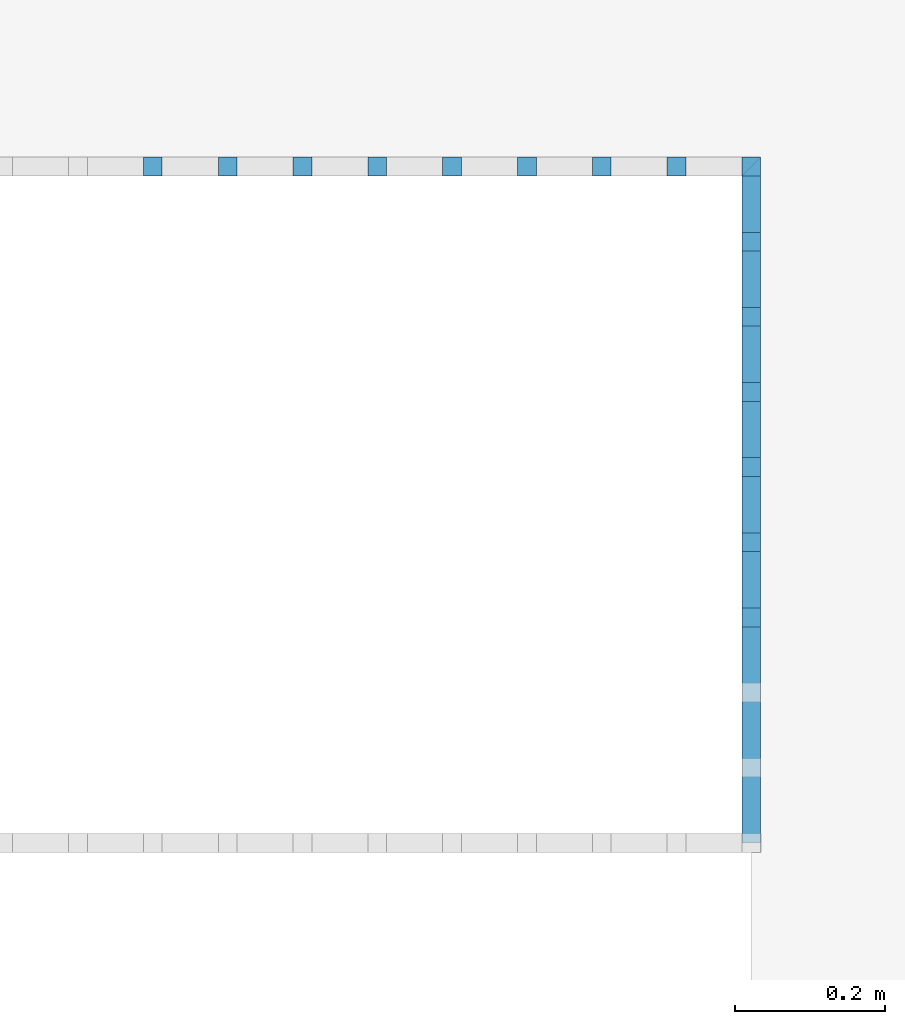
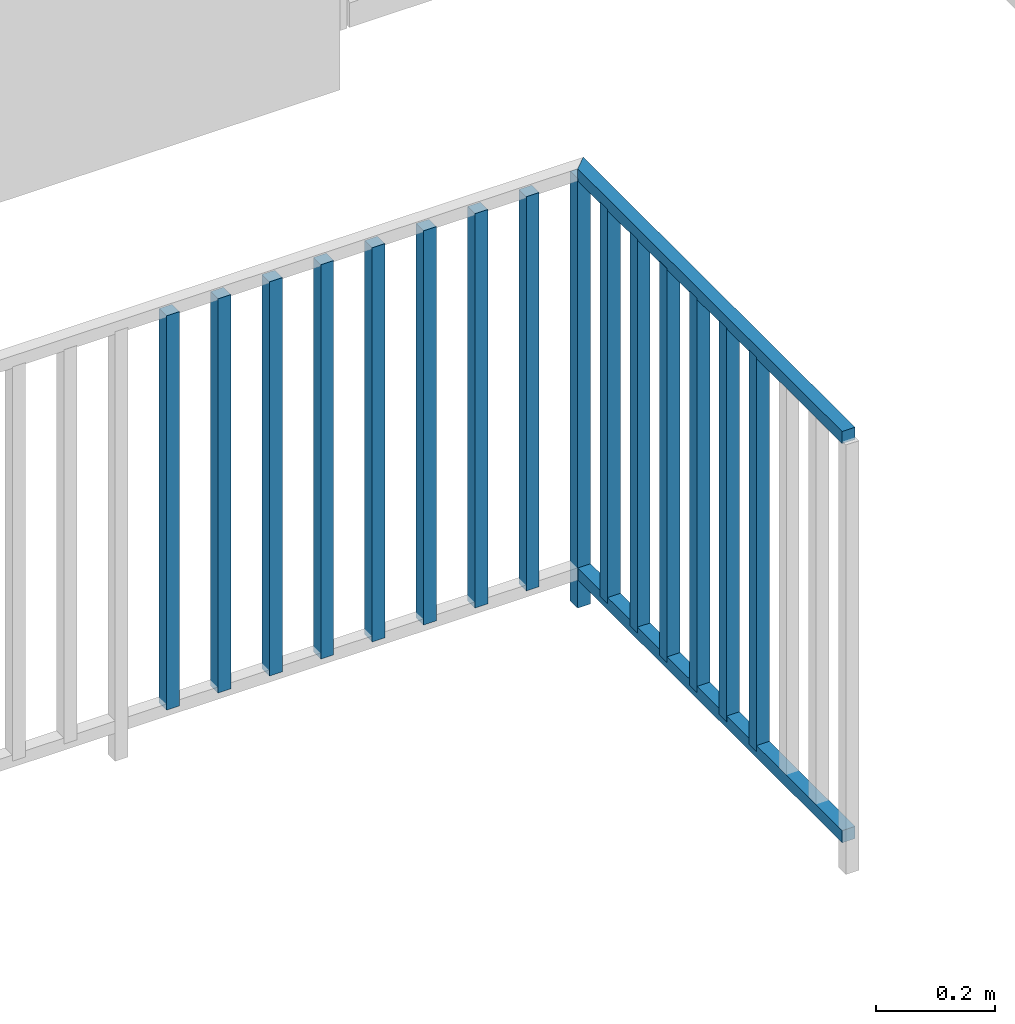
# One storey, part 41 of 54: 17 building element parts, 1 element without a shape of its own.
"""IFC4 building model written with IfcOpenShell, lengths in metres."""

from ifc_helpers import new_model, entity, si_unit, converted_unit, derived_unit, direction, frame, origin_with_axes, place, context, subcontext, project, spatial, polygons, material, type_object, element, aggregate, save


model = new_model("IFC4")

# Units and contexts
model_context = context("Model", 3, precision=1e-05, world=origin_with_axes(), true_north=direction((0.0, 1.0)))
body_context = subcontext(model_context, "Body", "Model", "MODEL_VIEW")
ifc_project = project(units=[si_unit("LENGTHUNIT", "METRE"), si_unit("AREAUNIT", "SQUARE_METRE"), si_unit("VOLUMEUNIT", "CUBIC_METRE"), converted_unit("PLANEANGLEUNIT", "DEGREE", entity("IfcPlaneAngleMeasure", 0.0174532925199), si_unit("PLANEANGLEUNIT", "RADIAN"), dimensions=[0, 0, 0, 0, 0, 0, 0]), converted_unit("TIMEUNIT", "Year", entity("IfcTimeMeasure", 31556926.0), si_unit("TIMEUNIT", "SECOND"), dimensions=[0, 0, 1, 0, 0, 0, 0]), si_unit("MASSUNIT", "GRAM", prefix="KILO"), si_unit("THERMODYNAMICTEMPERATUREUNIT", "DEGREE_CELSIUS"), si_unit("LUMINOUSINTENSITYUNIT", "LUMEN"), si_unit("ENERGYUNIT", "JOULE", prefix="MEGA"), derived_unit("THERMALCONDUCTANCEUNIT", [(si_unit("POWERUNIT", "WATT"), 1), (si_unit("LENGTHUNIT", "METRE"), -1), (si_unit("THERMODYNAMICTEMPERATUREUNIT", "KELVIN"), -1)]), derived_unit("SPECIFICHEATCAPACITYUNIT", [(si_unit("ENERGYUNIT", "JOULE"), 1), (si_unit("MASSUNIT", "GRAM", prefix="KILO"), -1), (si_unit("THERMODYNAMICTEMPERATUREUNIT", "KELVIN"), -1)]), derived_unit("MASSDENSITYUNIT", [(si_unit("MASSUNIT", "GRAM", prefix="KILO"), 1), (si_unit("VOLUMEUNIT", "CUBIC_METRE"), -1)])], contexts=[model_context])

# Site, building, storey, space
site_placement = place(None, origin_with_axes())
site = spatial("IfcSite", under=ifc_project, at=site_placement, CompositionType="ELEMENT")
building_placement = place(site_placement, origin_with_axes())
building = spatial("IfcBuilding", under=site, at=building_placement, CompositionType="ELEMENT")
storey_placement = place(building_placement, frame((0.0, 0.0, 6.29), z_axis=(0.0, 0.0, 1.0), x_axis=(1.0, 0.0, 0.0)))
storey = spatial("IfcBuildingStorey", under=building, at=storey_placement, Name="2. Geschoss", CompositionType="ELEMENT", Elevation=6.29)
space_placement = place(storey_placement, frame((-3.4421993804, -2.52881223104, 0.0), z_axis=(0.0, 0.0, 1.0), x_axis=(1.0, 0.0, 0.0)))
space = spatial("IfcSpace", under=storey, at=space_placement, CompositionType="ELEMENT", PredefinedType="INTERNAL")

# Railing, building element parts
railing_type = type_object("IfcRailingType", PredefinedType="NOTDEFINED")
railing_placement = place(space_placement, frame((0.0, 1.5, 0.0), z_axis=(0.0, 0.0, 1.0), x_axis=(1.0, 0.0, 0.0)))
railing = element("IfcRailing", 1, at=railing_placement, inside=space, type_object=railing_type, PredefinedType="NOTDEFINED")
ifc_material = material()
building_element_part_1_placement = place(railing_placement, origin_with_axes())
building_element_part_1 = element("IfcBuildingElementPart", 2, at=building_element_part_1_placement, material=ifc_material, PredefinedType="NOTDEFINED", context=body_context, shape_type="Tessellation", body=[
    polygons([(4.4925, 0.8875, 0.0), (4.4925, 0.9125, 0.0), (4.4925, 0.9125, 0.88), (4.4925, 0.8875, 0.88), (4.4675, 0.8875, 0.0), (4.4675, 0.9125, 0.0), (4.4675, 0.9125, 0.88), (4.4675, 0.8875, 0.88)], [[[1, 2, 3, 4]], [[1, 5, 6, 2]], [[2, 6, 7, 3]], [[4, 3, 7, 8]], [[5, 1, 4, 8]], [[6, 5, 8, 7]]], closed=True),
])
building_element_part_2_placement = place(railing_placement, origin_with_axes())
building_element_part_2 = element("IfcBuildingElementPart", 3, at=building_element_part_2_placement, material=ifc_material, PredefinedType="NOTDEFINED", context=body_context, shape_type="Tessellation", body=[
    polygons([(3.69605555556, 0.8875, 0.07), (3.69605555556, 0.9125, 0.07), (3.69605555556, 0.9125, 0.8775), (3.69605555556, 0.8875, 0.8775), (3.67105555556, 0.8875, 0.07), (3.67105555556, 0.9125, 0.07), (3.67105555556, 0.9125, 0.8775), (3.67105555556, 0.8875, 0.8775)], [[[1, 2, 3, 4]], [[1, 5, 6, 2]], [[2, 6, 7, 3]], [[4, 3, 7, 8]], [[5, 1, 4, 8]], [[6, 5, 8, 7]]], closed=True),
])
building_element_part_3_placement = place(railing_placement, origin_with_axes())
building_element_part_3 = element("IfcBuildingElementPart", 4, at=building_element_part_3_placement, material=ifc_material, PredefinedType="NOTDEFINED", context=body_context, shape_type="Tessellation", body=[
    polygons([(3.79561111111, 0.8875, 0.07), (3.79561111111, 0.9125, 0.07), (3.79561111111, 0.9125, 0.8775), (3.79561111111, 0.8875, 0.8775), (3.77061111111, 0.8875, 0.07), (3.77061111111, 0.9125, 0.07), (3.77061111111, 0.9125, 0.8775), (3.77061111111, 0.8875, 0.8775)], [[[1, 2, 3, 4]], [[1, 5, 6, 2]], [[2, 6, 7, 3]], [[4, 3, 7, 8]], [[5, 1, 4, 8]], [[6, 5, 8, 7]]], closed=True),
])
building_element_part_4_placement = place(railing_placement, origin_with_axes())
building_element_part_4 = element("IfcBuildingElementPart", 5, at=building_element_part_4_placement, material=ifc_material, PredefinedType="NOTDEFINED", context=body_context, shape_type="Tessellation", body=[
    polygons([(3.89516666667, 0.8875, 0.07), (3.89516666667, 0.9125, 0.07), (3.89516666667, 0.9125, 0.8775), (3.89516666667, 0.8875, 0.8775), (3.87016666667, 0.8875, 0.07), (3.87016666667, 0.9125, 0.07), (3.87016666667, 0.9125, 0.8775), (3.87016666667, 0.8875, 0.8775)], [[[1, 2, 3, 4]], [[1, 5, 6, 2]], [[2, 6, 7, 3]], [[4, 3, 7, 8]], [[5, 1, 4, 8]], [[6, 5, 8, 7]]], closed=True),
])
building_element_part_5_placement = place(railing_placement, origin_with_axes())
building_element_part_5 = element("IfcBuildingElementPart", 6, at=building_element_part_5_placement, material=ifc_material, PredefinedType="NOTDEFINED", context=body_context, shape_type="Tessellation", body=[
    polygons([(3.99472222222, 0.8875, 0.07), (3.99472222222, 0.9125, 0.07), (3.99472222222, 0.9125, 0.8775), (3.99472222222, 0.8875, 0.8775), (3.96972222222, 0.8875, 0.07), (3.96972222222, 0.9125, 0.07), (3.96972222222, 0.9125, 0.8775), (3.96972222222, 0.8875, 0.8775)], [[[1, 2, 3, 4]], [[1, 5, 6, 2]], [[2, 6, 7, 3]], [[4, 3, 7, 8]], [[5, 1, 4, 8]], [[6, 5, 8, 7]]], closed=True),
])
building_element_part_6_placement = place(railing_placement, origin_with_axes())
building_element_part_6 = element("IfcBuildingElementPart", 7, at=building_element_part_6_placement, material=ifc_material, PredefinedType="NOTDEFINED", context=body_context, shape_type="Tessellation", body=[
    polygons([(4.09427777778, 0.8875, 0.07), (4.09427777778, 0.9125, 0.07), (4.09427777778, 0.9125, 0.8775), (4.09427777778, 0.8875, 0.8775), (4.06927777778, 0.8875, 0.07), (4.06927777778, 0.9125, 0.07), (4.06927777778, 0.9125, 0.8775), (4.06927777778, 0.8875, 0.8775)], [[[1, 2, 3, 4]], [[1, 5, 6, 2]], [[2, 6, 7, 3]], [[4, 3, 7, 8]], [[5, 1, 4, 8]], [[6, 5, 8, 7]]], closed=True),
])
building_element_part_7_placement = place(railing_placement, origin_with_axes())
building_element_part_7 = element("IfcBuildingElementPart", 8, at=building_element_part_7_placement, material=ifc_material, PredefinedType="NOTDEFINED", context=body_context, shape_type="Tessellation", body=[
    polygons([(4.19383333333, 0.8875, 0.07), (4.19383333333, 0.9125, 0.07), (4.19383333333, 0.9125, 0.8775), (4.19383333333, 0.8875, 0.8775), (4.16883333333, 0.8875, 0.07), (4.16883333333, 0.9125, 0.07), (4.16883333333, 0.9125, 0.8775), (4.16883333333, 0.8875, 0.8775)], [[[1, 2, 3, 4]], [[1, 5, 6, 2]], [[2, 6, 7, 3]], [[4, 3, 7, 8]], [[5, 1, 4, 8]], [[6, 5, 8, 7]]], closed=True),
])
building_element_part_8_placement = place(railing_placement, origin_with_axes())
building_element_part_8 = element("IfcBuildingElementPart", 9, at=building_element_part_8_placement, material=ifc_material, PredefinedType="NOTDEFINED", context=body_context, shape_type="Tessellation", body=[
    polygons([(4.29338888889, 0.8875, 0.07), (4.29338888889, 0.9125, 0.07), (4.29338888889, 0.9125, 0.8775), (4.29338888889, 0.8875, 0.8775), (4.26838888889, 0.8875, 0.07), (4.26838888889, 0.9125, 0.07), (4.26838888889, 0.9125, 0.8775), (4.26838888889, 0.8875, 0.8775)], [[[1, 2, 3, 4]], [[1, 5, 6, 2]], [[2, 6, 7, 3]], [[4, 3, 7, 8]], [[5, 1, 4, 8]], [[6, 5, 8, 7]]], closed=True),
])
building_element_part_9_placement = place(railing_placement, origin_with_axes())
building_element_part_9 = element("IfcBuildingElementPart", 10, at=building_element_part_9_placement, material=ifc_material, PredefinedType="NOTDEFINED", context=body_context, shape_type="Tessellation", body=[
    polygons([(4.39294444444, 0.8875, 0.07), (4.39294444444, 0.9125, 0.07), (4.39294444444, 0.9125, 0.8775), (4.39294444444, 0.8875, 0.8775), (4.36794444444, 0.8875, 0.07), (4.36794444444, 0.9125, 0.07), (4.36794444444, 0.9125, 0.8775), (4.36794444444, 0.8875, 0.8775)], [[[1, 2, 3, 4]], [[1, 5, 6, 2]], [[2, 6, 7, 3]], [[4, 3, 7, 8]], [[5, 1, 4, 8]], [[6, 5, 8, 7]]], closed=True),
])
building_element_part_10_placement = place(railing_placement, origin_with_axes())
building_element_part_10 = element("IfcBuildingElementPart", 11, at=building_element_part_10_placement, material=ifc_material, PredefinedType="NOTDEFINED", context=body_context, shape_type="Tessellation", body=[
    polygons([(4.4675, 0.8875, 0.9), (4.4675, 0.8875, 0.875), (4.4675, 0.0, 0.875), (4.4675, 0.0, 0.9), (4.4925, 0.9125, 0.9), (4.4925, 0.9125, 0.875), (4.4925, 0.0, 0.875), (4.4925, 0.0, 0.9)], [[[1, 2, 3, 4]], [[1, 5, 6, 2]], [[2, 6, 7, 3]], [[4, 3, 7, 8]], [[5, 1, 4, 8]], [[6, 5, 8, 7]]], closed=True),
])
building_element_part_11_placement = place(railing_placement, origin_with_axes())
building_element_part_11 = element("IfcBuildingElementPart", 12, at=building_element_part_11_placement, material=ifc_material, PredefinedType="NOTDEFINED", context=body_context, shape_type="Tessellation", body=[
    polygons([(4.4675, 0.8875, 0.0825), (4.4675, 0.8875, 0.0575), (4.4675, 0.0, 0.0575), (4.4675, 0.0, 0.0825), (4.4925, 0.9125, 0.0825), (4.4925, 0.9125, 0.0575), (4.4925, 0.0, 0.0575), (4.4925, 0.0, 0.0825)], [[[1, 2, 3, 4]], [[1, 5, 6, 2]], [[2, 6, 7, 3]], [[4, 3, 7, 8]], [[5, 1, 4, 8]], [[6, 5, 8, 7]]], closed=True),
])
building_element_part_12_placement = place(railing_placement, origin_with_axes())
building_element_part_12 = element("IfcBuildingElementPart", 13, at=building_element_part_12_placement, material=ifc_material, PredefinedType="NOTDEFINED", context=body_context, shape_type="Tessellation", body=[
    polygons([(4.4675, 0.7875, 0.07), (4.4925, 0.7875, 0.07), (4.4925, 0.7875, 0.8775), (4.4675, 0.7875, 0.8775), (4.4675, 0.8125, 0.07), (4.4925, 0.8125, 0.07), (4.4925, 0.8125, 0.8775), (4.4675, 0.8125, 0.8775)], [[[1, 2, 3, 4]], [[1, 5, 6, 2]], [[2, 6, 7, 3]], [[4, 3, 7, 8]], [[5, 1, 4, 8]], [[6, 5, 8, 7]]], closed=True),
])
building_element_part_13_placement = place(railing_placement, origin_with_axes())
building_element_part_13 = element("IfcBuildingElementPart", 14, at=building_element_part_13_placement, material=ifc_material, PredefinedType="NOTDEFINED", context=body_context, shape_type="Tessellation", body=[
    polygons([(4.4675, 0.6875, 0.07), (4.4925, 0.6875, 0.07), (4.4925, 0.6875, 0.8775), (4.4675, 0.6875, 0.8775), (4.4675, 0.7125, 0.07), (4.4925, 0.7125, 0.07), (4.4925, 0.7125, 0.8775), (4.4675, 0.7125, 0.8775)], [[[1, 2, 3, 4]], [[1, 5, 6, 2]], [[2, 6, 7, 3]], [[4, 3, 7, 8]], [[5, 1, 4, 8]], [[6, 5, 8, 7]]], closed=True),
])
building_element_part_14_placement = place(railing_placement, origin_with_axes())
building_element_part_14 = element("IfcBuildingElementPart", 15, at=building_element_part_14_placement, material=ifc_material, PredefinedType="NOTDEFINED", context=body_context, shape_type="Tessellation", body=[
    polygons([(4.4675, 0.5875, 0.07), (4.4925, 0.5875, 0.07), (4.4925, 0.5875, 0.8775), (4.4675, 0.5875, 0.8775), (4.4675, 0.6125, 0.07), (4.4925, 0.6125, 0.07), (4.4925, 0.6125, 0.8775), (4.4675, 0.6125, 0.8775)], [[[1, 2, 3, 4]], [[1, 5, 6, 2]], [[2, 6, 7, 3]], [[4, 3, 7, 8]], [[5, 1, 4, 8]], [[6, 5, 8, 7]]], closed=True),
])
building_element_part_15_placement = place(railing_placement, origin_with_axes())
building_element_part_15 = element("IfcBuildingElementPart", 16, at=building_element_part_15_placement, material=ifc_material, PredefinedType="NOTDEFINED", context=body_context, shape_type="Tessellation", body=[
    polygons([(4.4675, 0.4875, 0.07), (4.4925, 0.4875, 0.07), (4.4925, 0.4875, 0.8775), (4.4675, 0.4875, 0.8775), (4.4675, 0.5125, 0.07), (4.4925, 0.5125, 0.07), (4.4925, 0.5125, 0.8775), (4.4675, 0.5125, 0.8775)], [[[1, 2, 3, 4]], [[1, 5, 6, 2]], [[2, 6, 7, 3]], [[4, 3, 7, 8]], [[5, 1, 4, 8]], [[6, 5, 8, 7]]], closed=True),
])
building_element_part_16_placement = place(railing_placement, origin_with_axes())
building_element_part_16 = element("IfcBuildingElementPart", 17, at=building_element_part_16_placement, material=ifc_material, PredefinedType="NOTDEFINED", context=body_context, shape_type="Tessellation", body=[
    polygons([(4.4675, 0.3875, 0.07), (4.4925, 0.3875, 0.07), (4.4925, 0.3875, 0.8775), (4.4675, 0.3875, 0.8775), (4.4675, 0.4125, 0.07), (4.4925, 0.4125, 0.07), (4.4925, 0.4125, 0.8775), (4.4675, 0.4125, 0.8775)], [[[1, 2, 3, 4]], [[1, 5, 6, 2]], [[2, 6, 7, 3]], [[4, 3, 7, 8]], [[5, 1, 4, 8]], [[6, 5, 8, 7]]], closed=True),
])
building_element_part_17_placement = place(railing_placement, origin_with_axes())
building_element_part_17 = element("IfcBuildingElementPart", 18, at=building_element_part_17_placement, material=ifc_material, PredefinedType="NOTDEFINED", context=body_context, shape_type="Tessellation", body=[
    polygons([(4.4675, 0.2875, 0.07), (4.4925, 0.2875, 0.07), (4.4925, 0.2875, 0.8775), (4.4675, 0.2875, 0.8775), (4.4675, 0.3125, 0.07), (4.4925, 0.3125, 0.07), (4.4925, 0.3125, 0.8775), (4.4675, 0.3125, 0.8775)], [[[1, 2, 3, 4]], [[1, 5, 6, 2]], [[2, 6, 7, 3]], [[4, 3, 7, 8]], [[5, 1, 4, 8]], [[6, 5, 8, 7]]], closed=True),
])
aggregate(railing, [building_element_part_1, building_element_part_2, building_element_part_3, building_element_part_4, building_element_part_5, building_element_part_6, building_element_part_7, building_element_part_8, building_element_part_9, building_element_part_10, building_element_part_11, building_element_part_12, building_element_part_13, building_element_part_14, building_element_part_15, building_element_part_16, building_element_part_17])

save(model, "model.ifc")
